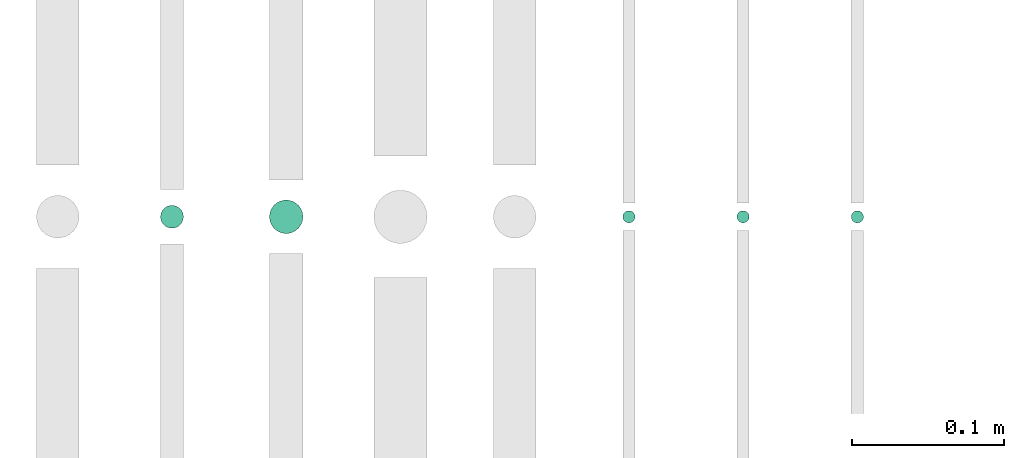
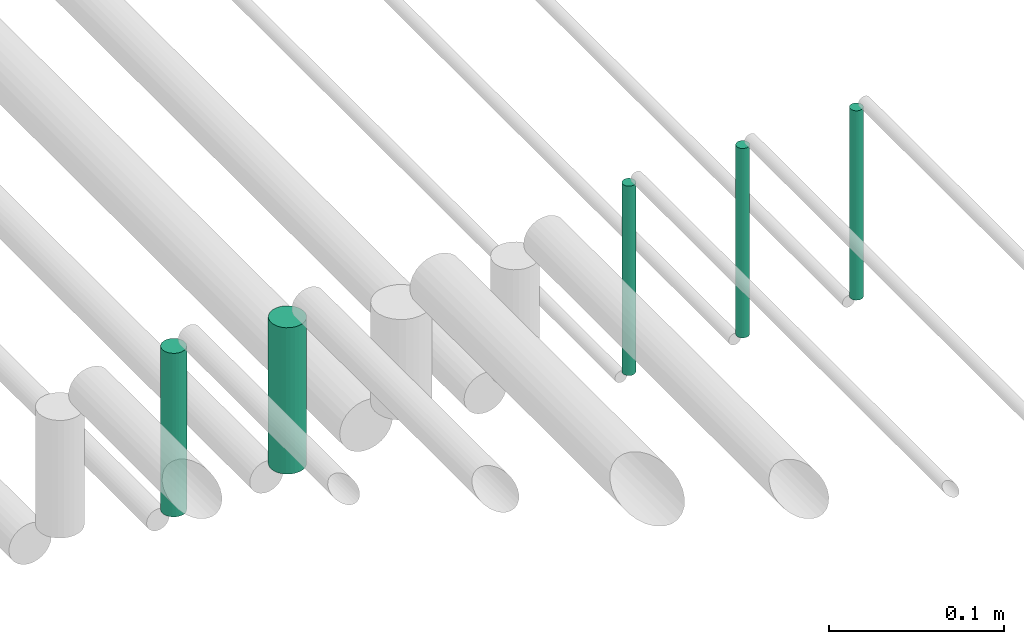
# One storey, part 210 of 331: 5 flow segments.
"""IFC2X3 building model written with IfcOpenShell, lengths in millimetres."""

from ifc_helpers import new_model, entity, si_unit, converted_unit, derived_unit, direction, frame, origin, origin_2d_with_axis, place, context, subcontext, project, spatial, circle, extrude, type_object, element, save


model = new_model("IFC2X3")

# Units and contexts
model_context = context("Model", 3, precision=0.01, world=origin(), true_north=direction((6.12303176911189e-17, 1.0)))
body_context = subcontext(model_context, "Body", "Model", "MODEL_VIEW")
ifc_project = project(units=[si_unit("LENGTHUNIT", "METRE", prefix="MILLI"), si_unit("AREAUNIT", "SQUARE_METRE"), si_unit("VOLUMEUNIT", "CUBIC_METRE"), converted_unit("PLANEANGLEUNIT", "DEGREE", entity("IfcRatioMeasure", 0.0174532925199433), si_unit("PLANEANGLEUNIT", "RADIAN"), dimensions=[0, 0, 0, 0, 0, 0, 0]), si_unit("MASSUNIT", "GRAM", prefix="KILO"), derived_unit("MASSDENSITYUNIT", [(si_unit("MASSUNIT", "GRAM", prefix="KILO"), 1), (si_unit("LENGTHUNIT", "METRE"), -3)]), derived_unit("MOMENTOFINERTIAUNIT", [(si_unit("LENGTHUNIT", "METRE"), 4)]), si_unit("TIMEUNIT", "SECOND"), si_unit("FREQUENCYUNIT", "HERTZ"), si_unit("THERMODYNAMICTEMPERATUREUNIT", "DEGREE_CELSIUS"), derived_unit("THERMALTRANSMITTANCEUNIT", [(si_unit("MASSUNIT", "GRAM", prefix="KILO"), 1), (si_unit("THERMODYNAMICTEMPERATUREUNIT", "KELVIN"), -1), (si_unit("TIMEUNIT", "SECOND"), -3)]), derived_unit("VOLUMETRICFLOWRATEUNIT", [(si_unit("LENGTHUNIT", "METRE"), 3), (si_unit("TIMEUNIT", "SECOND"), -1)]), derived_unit("MASSFLOWRATEUNIT", [(si_unit("MASSUNIT", "GRAM", prefix="KILO"), 1), (si_unit("TIMEUNIT", "SECOND"), -1)]), derived_unit("ROTATIONALFREQUENCYUNIT", [(si_unit("TIMEUNIT", "SECOND"), -1)]), si_unit("ELECTRICCURRENTUNIT", "AMPERE"), si_unit("ELECTRICVOLTAGEUNIT", "VOLT"), si_unit("POWERUNIT", "WATT"), si_unit("FORCEUNIT", "NEWTON", prefix="KILO"), si_unit("ILLUMINANCEUNIT", "LUX"), si_unit("LUMINOUSFLUXUNIT", "LUMEN"), si_unit("LUMINOUSINTENSITYUNIT", "CANDELA"), derived_unit("USERDEFINED", [(si_unit("MASSUNIT", "GRAM", prefix="KILO"), -1), (si_unit("LENGTHUNIT", "METRE"), -2), (si_unit("TIMEUNIT", "SECOND"), 3), (si_unit("LUMINOUSFLUXUNIT", "LUMEN"), 1)]), derived_unit("LINEARVELOCITYUNIT", [(si_unit("LENGTHUNIT", "METRE"), 1), (si_unit("TIMEUNIT", "SECOND"), -1)]), si_unit("PRESSUREUNIT", "PASCAL"), derived_unit("USERDEFINED", [(si_unit("LENGTHUNIT", "METRE"), -2), (si_unit("MASSUNIT", "GRAM", prefix="KILO"), 1), (si_unit("TIMEUNIT", "SECOND"), -2)]), derived_unit("LINEARFORCEUNIT", [(si_unit("MASSUNIT", "GRAM", prefix="KILO"), 1), (si_unit("LENGTHUNIT", "METRE"), 1), (si_unit("TIMEUNIT", "SECOND"), -2), (si_unit("LENGTHUNIT", "METRE"), -1)]), derived_unit("PLANARFORCEUNIT", [(si_unit("MASSUNIT", "GRAM", prefix="KILO"), 1), (si_unit("LENGTHUNIT", "METRE"), 1), (si_unit("TIMEUNIT", "SECOND"), -2), (si_unit("LENGTHUNIT", "METRE"), -2)])], contexts=[model_context])

# Site, building, storey
site_placement = place(None, frame((0.0, -0.00077364408347762, 0.0)))
site = spatial("IfcSite", under=ifc_project, at=site_placement, CompositionType="ELEMENT")
building_placement = place(site_placement, origin())
building = spatial("IfcBuilding", under=site, at=building_placement, CompositionType="ELEMENT")
storey_placement = place(building_placement, origin())
storey = spatial("IfcBuildingStorey", under=building, at=storey_placement, CompositionType="ELEMENT", Elevation=0.0)

# Flow segments
pipe_segment_type = type_object("IfcPipeSegmentType", PredefinedType="NOTDEFINED")
flow_segment_1_placement = place(building_placement, frame((65391.016630958, 2565.90467691472, 2718.0)))
element("IfcFlowSegment", 1, at=flow_segment_1_placement, inside=storey, type_object=pipe_segment_type, context=body_context, shape_type="SweptSolid", body=[
    extrude(circle(Radius=7.5, at=origin_2d_with_axis()), frame((9.09527223591419, 9.09527223591582, 0.0), z_axis=(0.0, 0.0, 1.0), x_axis=(-1.0, 0.0, 0.0)), (0.0, 0.0, 1.0), 114.000000000013),
])
flow_segment_2_placement = place(building_placement, frame((65462.516630958, 2562.40467691472, 2724.0)))
element("IfcFlowSegment", 2, at=flow_segment_2_placement, inside=storey, type_object=pipe_segment_type, context=body_context, shape_type="SweptSolid", body=[
    extrude(circle(Radius=11.0, at=origin_2d_with_axis()), frame((12.5952722359134, 12.5952722359161, 0.0), z_axis=(0.0, 0.0, 1.0), x_axis=(-1.0, 0.0, 0.0)), (0.0, 0.0, 1.0), 102.000000000013),
])
for number, where in (
    (3, (65694.516630958, 2569.40467691472, 2709.0)),
    (4, (65769.516630958, 2569.40467691472, 2709.0)),
):
    element("IfcFlowSegment", number, at=place(building_placement, frame(where)), inside=storey, type_object=pipe_segment_type, context=body_context, shape_type="SweptSolid", body=[
        extrude(circle(Radius=4.0, at=origin_2d_with_axis()), frame((5.59527223591499, 5.59527223591607, 0.0), z_axis=(0.0, 0.0, 1.0), x_axis=(-1.0, 0.0, 0.0)), (0.0, 0.0, 1.0), 132.00000000003),
    ])
flow_segment_3_placement = place(building_placement, frame((65844.516630958, 2569.40467691472, 2709.0)))
element("IfcFlowSegment", 5, at=flow_segment_3_placement, inside=storey, type_object=pipe_segment_type, context=body_context, shape_type="SweptSolid", body=[
    extrude(circle(Radius=4.0, at=origin_2d_with_axis()), frame((5.59527223591499, 5.59527223591607, 0.0), z_axis=(0.0, 0.0, 1.0), x_axis=(-1.0, 0.0, 0.0)), (0.0, 0.0, 1.0), 132.000000000006),
])

save(model, "model.ifc")
